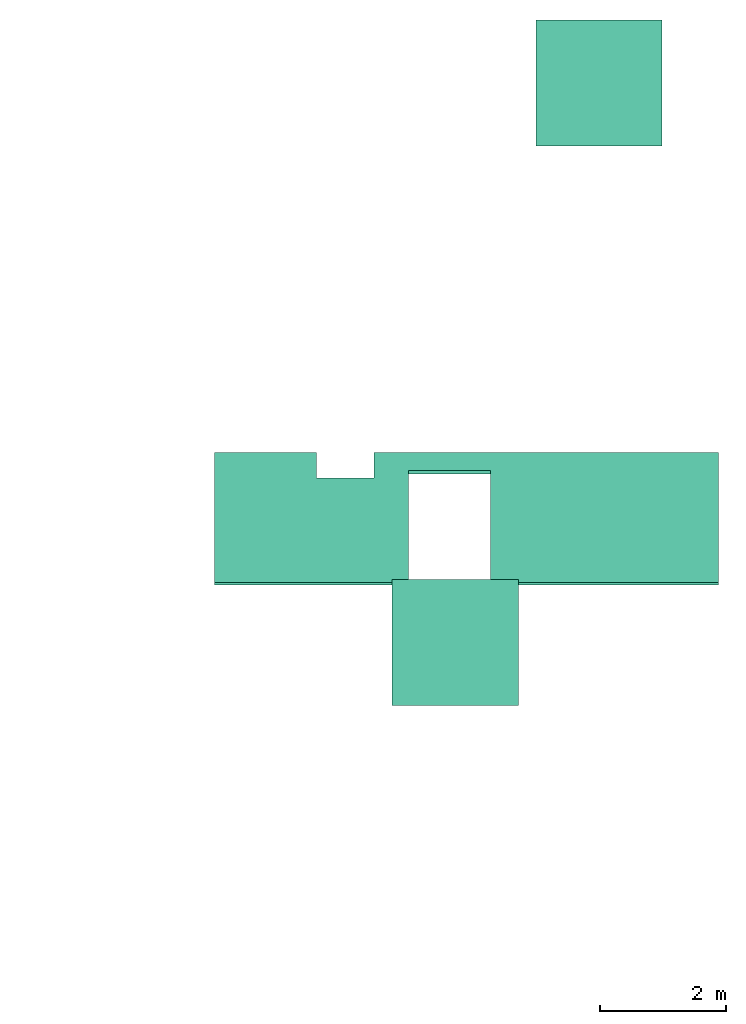
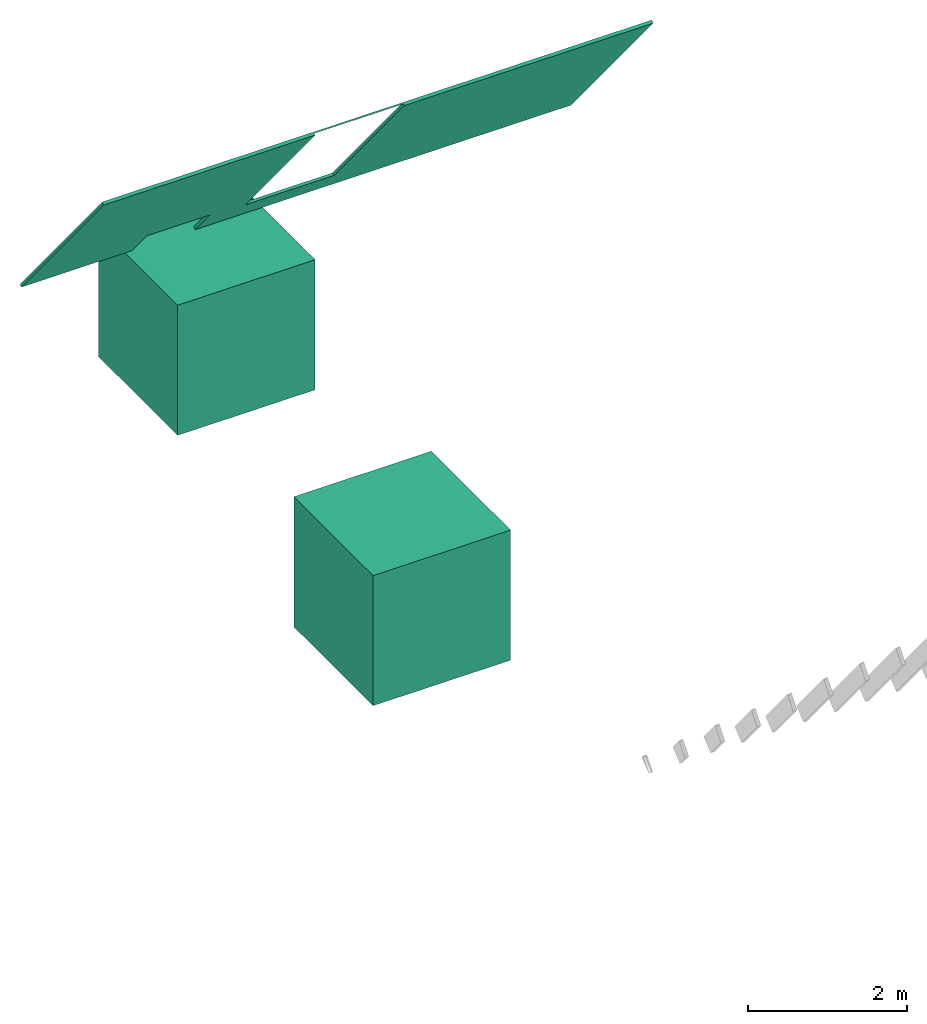
# Not in any storey, part 4 of 4: 3 actuators.
"""IFC4 model written with IfcOpenShell, lengths in metres."""

from ifc_helpers import new_model, entity, si_unit, converted_unit, frame, frame_2d, origin_with_axes, place, context, project, polygons, shape, element, save


model = new_model("IFC4")

# Units and contexts
model_context = context("Model", 3, precision=1e-05, world=origin_with_axes())
plan_context = context("Plan", 2, precision=1e-05, world=frame_2d((0.0, 0.0, 0.0), x_axis=(1.0, 0.0, 0.0)))
ifc_project = project(units=[si_unit("AREAUNIT", "SQUARE_METRE"), si_unit("VOLUMEUNIT", "CUBIC_METRE"), si_unit("LENGTHUNIT", "METRE"), converted_unit("PLANEANGLEUNIT", "degree", entity("IfcReal", 0.0174532925199433), si_unit("PLANEANGLEUNIT", "RADIAN"), dimensions=[0, 0, 0, 0, 0, 0, 0])], contexts=[model_context, plan_context])

# Actuators
for number, where, z_axis, x_axis, name in (
    (1, (2.28017997741699, 8.87300395965576, -2.02162146568298), (0.0, 0.0, 1.0), (1.0, 0.0, 0.0), "Cube"),
    (2, (0.0, 0.0, 0.0), (0.0, 0.0, 1.0), (1.0, 0.0, 0.0), "Cube"),
):
    element("IfcActuator", number, at=place(None, frame(where, z_axis=z_axis, x_axis=x_axis)), Name=name, PredefinedType="ELECTRICACTUATOR", shapes=[
        shape(model_context, None, "Tessellation", [polygons([(-1.0, -1.0, -1.0), (-1.0, -1.0, 1.0), (-1.0, 1.0, -1.0), (-1.0, 1.0, 1.0), (1.0, -1.0, -1.0), (1.0, -1.0, 1.0), (1.0, 1.0, -1.0), (1.0, 1.0, 1.0)], [[[1, 2, 4, 3]], [[3, 4, 8, 7]], [[7, 8, 6, 5]], [[5, 6, 2, 1]], [[3, 7, 5, 1]], [[8, 4, 2, 6]]])]),
    ])
actuator_placement = place(None, frame((2.94633889198303, 1.98802328109741, 5.25050783157349), z_axis=(2.88761242472901e-07, -0.772404372692108, -0.635131061077118), x_axis=(1.0, 2.88761214051192e-07, 1.03475983337376e-07)))
element("IfcActuator", 3, at=actuator_placement, Name="Ceiling.002", PredefinedType="ELECTRICACTUATOR", shapes=[
    shape(model_context, None, "Tessellation", [polygons([(-6.76313018798828, -1.59362435340881, -0.0222694482654333), (-6.76313018798828, 1.66154062747955, -0.0222694482654333), (-6.76313018798828, -1.59362435340881, 0.0222678985446692), (-6.76313018798828, 1.66154062747955, 0.0222678985446692), (-2.39136481285095, 1.66154074668884, 0.0222682971507311), (-2.39136481285095, 1.66154074668884, -0.00102295319084078), (1.23025751113892, 1.66154086589813, 0.0222685318440199), (1.23025751113892, 1.66154086589813, -0.0222688149660826), (-3.68647432327271, 1.66154074668884, 0.0222681798040867), (-3.68647432327271, 1.66154074668884, -0.00102299742866307), (1.23025751113892, -1.59362411499023, -0.0222688149660826), (1.23025751113892, -1.59362411499023, 0.0222685318440199), (-5.14753866195679, -1.59362435340881, 0.0222680456936359), (-5.14753866195679, -1.59362435340881, -0.0222693011164665), (-4.23423624038696, -1.59362423419952, -0.0222692172974348), (-4.23423624038696, -1.59362423419952, 0.0222681295126677), (-4.23423624038696, -0.953339755535126, -0.0222692172974348), (-3.68647432327271, -1.14009618759155, -0.0222691670060158), (-5.14753866195679, -0.953339636325836, -0.0222693011164665), (-3.36333894729614, -1.14009618759155, -0.0222691372036934), (-2.39136481285095, -1.14009606838226, -0.0222690496593714), (-2.39136481285095, 1.64407050609589, -0.0222690496593714), (-3.68647432327271, 1.64407050609589, -0.0222691670060158), (-3.68647432327271, -1.10347414016724, 0.0222681798040867), (-2.39136481285095, -1.10347402095795, 0.0222682971507311), (-5.14753866195679, -1.00750303268433, 0.0222680456936359), (-4.23423624038696, -1.00750315189362, 0.0222681295126677)], [[[15, 11, 12, 16]], [[22, 8, 11, 21]], [[9, 10, 2, 4]], [[8, 2, 6]], [[6, 2, 10]], [[17, 27, 26, 19]], [[10, 23, 22, 6]], [[8, 7, 12, 11]], [[25, 12, 7, 5]], [[15, 20, 21]], [[15, 21, 11]], [[1, 19, 14]], [[23, 9, 24, 18]], [[2, 19, 1]], [[2, 8, 23]], [[23, 8, 22]], [[23, 18, 17]], [[15, 18, 20]], [[17, 18, 15]], [[26, 3, 13]], [[4, 3, 26]], [[24, 27, 16]], [[25, 24, 16]], [[2, 23, 17, 19]], [[9, 27, 24]], [[12, 25, 16]], [[9, 4, 26, 27]], [[14, 19, 26]], [[13, 14, 26]], [[15, 27, 17]], [[15, 16, 27]], [[3, 1, 14, 13]], [[9, 23, 10]], [[21, 25, 5, 22]], [[22, 5, 6]], [[7, 8, 6, 5]], [[20, 18, 24]], [[25, 21, 20]], [[24, 25, 20]], [[4, 2, 1, 3]]])]),
])

save(model, "model.ifc")
